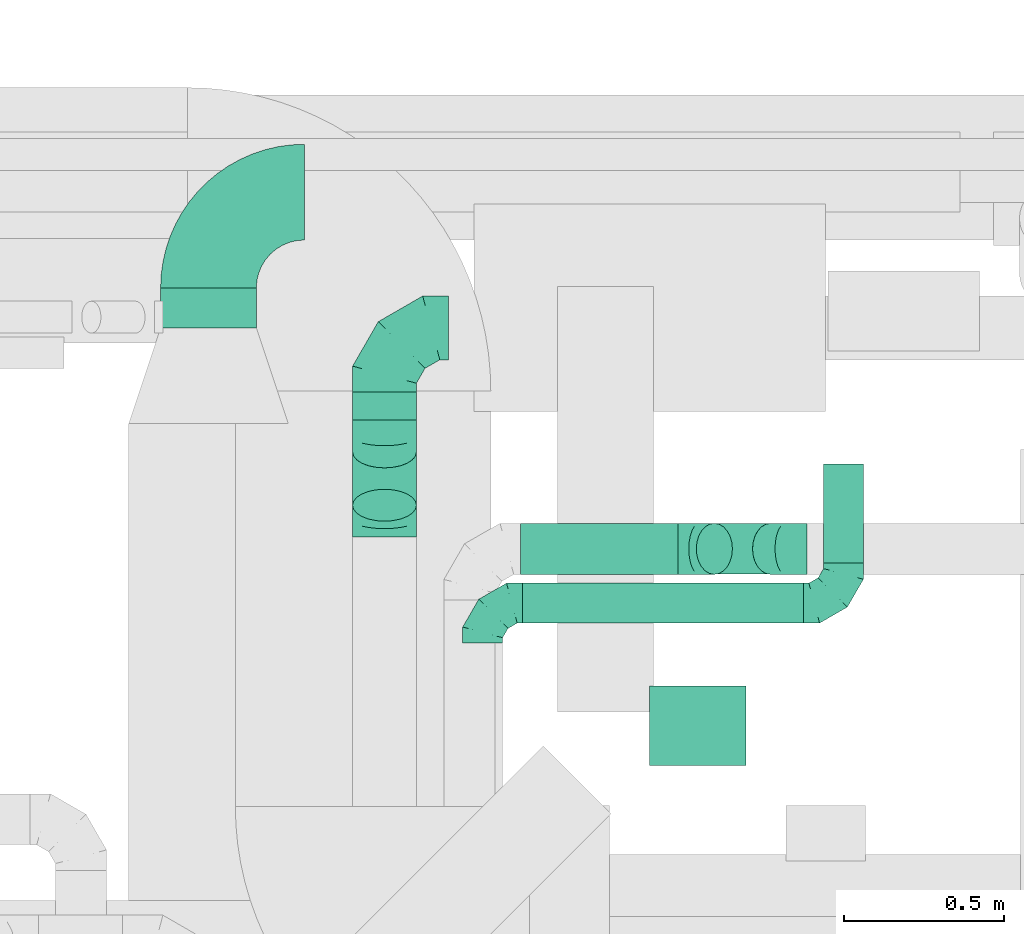
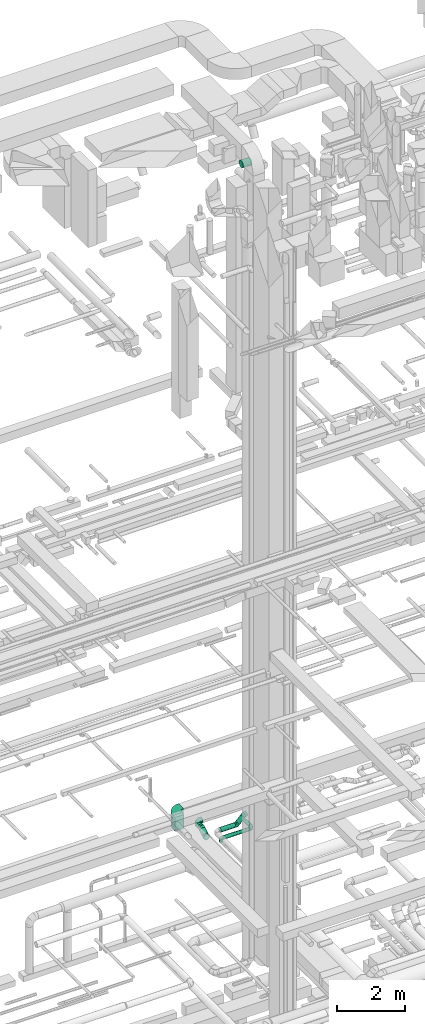
# One storey, part 280 of 337: 8 flow fittings, 8 flow segments.
"""IFC2X3 building model written with IfcOpenShell, lengths in millimetres."""

from ifc_helpers import new_model, entity, si_unit, converted_unit, derived_unit, direction, frame, frame_2d, origin, origin_2d_with_axis, place, context, subcontext, project, spatial, polyline, circle_curve, parameter, trimmed, segment, composite_curve, rectangle, circle, outline, extrude, faceted_brep, source, transform, mapped, material, type_object, type_shapes, element, save


model = new_model("IFC2X3")

# Units and contexts
model_context = context("Model", 3, precision=0.01, world=origin(), true_north=direction((6.12303176911189e-17, 1.0)))
body_context = subcontext(model_context, "Body", "Model", "MODEL_VIEW")
ifc_project = project(units=[si_unit("LENGTHUNIT", "METRE", prefix="MILLI"), si_unit("AREAUNIT", "SQUARE_METRE"), si_unit("VOLUMEUNIT", "CUBIC_METRE"), converted_unit("PLANEANGLEUNIT", "DEGREE", entity("IfcRatioMeasure", 0.0174532925199433), si_unit("PLANEANGLEUNIT", "RADIAN"), dimensions=[0, 0, 0, 0, 0, 0, 0]), si_unit("MASSUNIT", "GRAM", prefix="KILO"), derived_unit("MASSDENSITYUNIT", [(si_unit("MASSUNIT", "GRAM", prefix="KILO"), 1), (si_unit("LENGTHUNIT", "METRE"), -3)]), derived_unit("MOMENTOFINERTIAUNIT", [(si_unit("LENGTHUNIT", "METRE"), 4)]), si_unit("TIMEUNIT", "SECOND"), si_unit("FREQUENCYUNIT", "HERTZ"), si_unit("THERMODYNAMICTEMPERATUREUNIT", "DEGREE_CELSIUS"), derived_unit("THERMALTRANSMITTANCEUNIT", [(si_unit("MASSUNIT", "GRAM", prefix="KILO"), 1), (si_unit("THERMODYNAMICTEMPERATUREUNIT", "KELVIN"), -1), (si_unit("TIMEUNIT", "SECOND"), -3)]), derived_unit("VOLUMETRICFLOWRATEUNIT", [(si_unit("LENGTHUNIT", "METRE"), 3), (si_unit("TIMEUNIT", "SECOND"), -1)]), derived_unit("MASSFLOWRATEUNIT", [(si_unit("MASSUNIT", "GRAM", prefix="KILO"), 1), (si_unit("TIMEUNIT", "SECOND"), -1)]), derived_unit("ROTATIONALFREQUENCYUNIT", [(si_unit("TIMEUNIT", "SECOND"), -1)]), si_unit("ELECTRICCURRENTUNIT", "AMPERE"), si_unit("ELECTRICVOLTAGEUNIT", "VOLT"), si_unit("POWERUNIT", "WATT"), si_unit("FORCEUNIT", "NEWTON", prefix="KILO"), si_unit("ILLUMINANCEUNIT", "LUX"), si_unit("LUMINOUSFLUXUNIT", "LUMEN"), si_unit("LUMINOUSINTENSITYUNIT", "CANDELA"), derived_unit("USERDEFINED", [(si_unit("MASSUNIT", "GRAM", prefix="KILO"), -1), (si_unit("LENGTHUNIT", "METRE"), -2), (si_unit("TIMEUNIT", "SECOND"), 3), (si_unit("LUMINOUSFLUXUNIT", "LUMEN"), 1)]), derived_unit("LINEARVELOCITYUNIT", [(si_unit("LENGTHUNIT", "METRE"), 1), (si_unit("TIMEUNIT", "SECOND"), -1)]), si_unit("PRESSUREUNIT", "PASCAL"), derived_unit("USERDEFINED", [(si_unit("LENGTHUNIT", "METRE"), -2), (si_unit("MASSUNIT", "GRAM", prefix="KILO"), 1), (si_unit("TIMEUNIT", "SECOND"), -2)]), derived_unit("LINEARFORCEUNIT", [(si_unit("MASSUNIT", "GRAM", prefix="KILO"), 1), (si_unit("LENGTHUNIT", "METRE"), 1), (si_unit("TIMEUNIT", "SECOND"), -2), (si_unit("LENGTHUNIT", "METRE"), -1)]), derived_unit("PLANARFORCEUNIT", [(si_unit("MASSUNIT", "GRAM", prefix="KILO"), 1), (si_unit("LENGTHUNIT", "METRE"), 1), (si_unit("TIMEUNIT", "SECOND"), -2), (si_unit("LENGTHUNIT", "METRE"), -2)])], contexts=[model_context])

# Site, building, storey
site_placement = place(None, origin())
site = spatial("IfcSite", under=ifc_project, at=site_placement, CompositionType="ELEMENT")
building_placement = place(site_placement, origin())
building = spatial("IfcBuilding", under=site, at=building_placement, CompositionType="ELEMENT")
storey_placement = place(building_placement, origin())
storey = spatial("IfcBuildingStorey", under=building, at=storey_placement, CompositionType="ELEMENT", Elevation=0.0)

# Flow segments
duct_segment_type_1 = type_object("IfcDuctSegmentType", PredefinedType="NOTDEFINED")
flow_segment_1_placement = place(storey_placement, frame((46175.84, 19371.07, 3200.0)))
element("IfcFlowSegment", 1, at=flow_segment_1_placement, inside=storey, type_object=duct_segment_type_1, context=body_context, shape_type="SweptSolid", body=[
    extrude(rectangle(XDim=125.172819427906, YDim=300.000000000001, at=origin_2d_with_axis()), frame((150.0, 62.59, 0.0), z_axis=(0.0, 0.0, 1.0), x_axis=(0.0, -1.0, 0.0)), (0.0, 0.0, 1.0), 500.0),
])
duct_segment_type_2 = type_object("IfcDuctSegmentType", PredefinedType="NOTDEFINED")
flow_segment_2_placement = place(storey_placement, frame((47309.59, 18445.02, 3035.9)))
element("IfcFlowSegment", 2, at=flow_segment_2_placement, inside=storey, type_object=duct_segment_type_2, context=body_context, shape_type="SweptSolid", body=[
    extrude(circle(Radius=62.5, at=origin_2d_with_axis()), frame((0.0, 64.1, 64.1), z_axis=(1.0, 0.0, 0.0), x_axis=(0.0, -1.0, 0.0)), (0.0, 0.0, 1.0), 880.000000000043),
])
flow_segment_3_placement = place(storey_placement, frame((47706.43, 17998.76, 27323.4)))
element("IfcFlowSegment", 3, at=flow_segment_3_placement, inside=storey, type_object=duct_segment_type_2, context=body_context, shape_type="SweptSolid", body=[
    extrude(circle(Radius=125.0, at=origin_2d_with_axis()), frame((0.0, 126.6, 126.6), z_axis=(1.0, 0.0, 0.0), x_axis=(0.0, -1.0, 0.0)), (0.0, 0.0, 1.0), 302.500000000001),
])
flow_segment_4_placement = place(storey_placement, frame((48250.5, 18634.11, 3035.9)))
element("IfcFlowSegment", 4, at=flow_segment_4_placement, inside=storey, type_object=duct_segment_type_2, context=body_context, shape_type="SweptSolid", body=[
    extrude(circle(Radius=62.5, at=origin_2d_with_axis()), frame((64.1, 0.0, 64.1), z_axis=(0.0, 1.0, 0.0), x_axis=(1.0, 0.0, 0.0)), (0.0, 0.0, 1.0), 310.00000000002),
])
flow_segment_5_placement = place(storey_placement, frame((47303.34, 18597.52, 3198.4)))
element("IfcFlowSegment", 5, at=flow_segment_5_placement, inside=storey, type_object=duct_segment_type_2, context=body_context, shape_type="SweptSolid", body=[
    extrude(circle(Radius=80.0, at=origin_2d_with_axis()), frame((0.0, 81.6, 81.6), z_axis=(1.0, 0.0, 0.0), x_axis=(0.0, -1.0, 0.0)), (0.0, 0.0, 1.0), 493.72583002049),
])
flow_segment_6_placement = place(storey_placement, frame((47852.04, 18597.52, 3268.7)))
element("IfcFlowSegment", 6, at=flow_segment_6_placement, inside=storey, type_object=duct_segment_type_2, context=body_context, shape_type="SweptSolid", body=[
    extrude(circle(Radius=80.0, at=origin_2d_with_axis()), frame((58.16, 81.6, 58.16), z_axis=(0.707106781186545, 0.0, 0.70710678118655), x_axis=(0.0, 1.0, 0.0)), (0.0, 0.0, 1.0), 249.289321881311),
])
flow_segment_7_placement = place(storey_placement, frame((46775.59, 19082.7, 3198.4)))
element("IfcFlowSegment", 7, at=flow_segment_7_placement, inside=storey, type_object=duct_segment_type_2, context=body_context, shape_type="SweptSolid", body=[
    extrude(circle(Radius=100.0, at=origin_2d_with_axis()), frame((101.6, 0.0, 101.6), z_axis=(0.0, 1.0, 0.0), x_axis=(-1.0, 0.0, 0.0)), (0.0, 0.0, 1.0), 88.3703419238146),
])
flow_segment_8_placement = place(storey_placement, frame((46775.59, 18764.12, 3088.6)))
element("IfcFlowSegment", 8, at=flow_segment_8_placement, inside=storey, type_object=duct_segment_type_2, context=body_context, shape_type="SweptSolid", body=[
    extrude(circle(Radius=100.0, at=origin_2d_with_axis()), frame((101.6, 51.6, 88.2), z_axis=(0.0, 0.866025410712643, 0.499999987999998), x_axis=(-1.0, 0.0, 0.0)), (0.0, 0.0, 1.0), 192.820333197818),
])

# Flow fittings
ifc_material = material()
duct_fitting_type_1 = type_object("IfcDuctFittingType", PredefinedType="NOTDEFINED", material=ifc_material)
shared_shape_1 = source(origin(), body_context, "Body", "Brep", [
    faceted_brep([(-200.0, 0.0, -100.0), (-200.0, -25.88, -96.59), (-200.0, -50.0, -86.6), (-200.0, -70.71, -70.71), (-200.0, -86.6, -50.0), (-200.0, -96.59, -25.88), (-200.0, -100.0, 0.0), (-200.0, -96.59, 25.88), (-200.0, -86.6, 50.0), (-200.0, -70.71, 70.71), (-200.0, -50.0, 86.6), (-200.0, -25.88, 96.59), (-200.0, 0.0, 100.0), (-200.0, 25.88, 96.59), (-200.0, 50.0, 86.6), (-200.0, 70.71, 70.71), (-200.0, 86.6, 50.0), (-200.0, 96.59, 25.88), (-200.0, 100.0, 0.0), (-200.0, 96.59, -25.88), (-200.0, 86.6, -50.0), (-200.0, 70.71, -70.71), (-200.0, 50.0, -86.6), (-200.0, 25.88, -96.59), (-153.35, 25.88, 96.59), (-159.81, 50.0, 86.6), (-146.41, 0.0, 100.0), (-165.36, 70.71, 70.71), (-172.29, 96.59, 25.88), (-173.21, 100.0, 0.0), (-169.62, 86.6, 50.0), (-169.62, 86.6, -50.0), (-165.36, 70.71, -70.71), (-172.29, 96.59, -25.88), (-153.35, 25.88, -96.59), (-146.41, 0.0, -100.0), (-159.81, 50.0, -86.6), (-139.48, -25.88, -96.59), (-133.01, -50.0, -86.6), (-127.46, -70.71, -70.71), (-123.21, -86.6, -50.0), (-120.53, -96.59, -25.88), (-119.62, -100.0, 0.0), (-120.53, -96.59, 25.88), (-123.21, -86.6, 50.0), (-127.46, -70.71, 70.71), (-133.01, -50.0, 86.6), (-139.48, -25.88, 96.59), (-72.54, 72.54, 96.59), (-90.19, 90.19, 86.6), (-53.59, 53.59, 100.0), (-105.35, 105.35, 70.71), (-116.99, 116.99, 50.0), (-124.3, 124.3, 25.88), (-126.79, 126.79, 0.0), (-124.3, 124.3, -25.88), (-116.99, 116.99, -50.0), (-105.35, 105.35, -70.71), (-72.54, 72.54, -96.59), (-53.59, 53.59, -100.0), (-90.19, 90.19, -86.6), (-34.64, 34.64, -96.59), (-16.99, 16.99, -86.6), (-1.83, 1.83, -70.71), (9.81, -9.81, -50.0), (17.12, -17.12, -25.88), (19.62, -19.62, 0.0), (17.12, -17.12, 25.88), (9.81, -9.81, 50.0), (-1.83, 1.83, 70.71), (-16.99, 16.99, 86.6), (-34.64, 34.64, 96.59), (-25.88, 153.35, 96.59), (-50.0, 159.81, 86.6), (0.0, 146.41, 100.0), (-70.71, 165.36, 70.71), (-86.6, 169.62, 50.0), (-96.59, 172.29, 25.88), (-100.0, 173.21, 0.0), (-96.59, 172.29, -25.88), (-86.6, 169.62, -50.0), (-70.71, 165.36, -70.71), (-25.88, 153.35, -96.59), (0.0, 146.41, -100.0), (-50.0, 159.81, -86.6), (25.88, 139.48, -96.59), (50.0, 133.01, -86.6), (70.71, 127.46, -70.71), (86.6, 123.21, -50.0), (96.59, 120.53, -25.88), (100.0, 119.62, 0.0), (96.59, 120.53, 25.88), (86.6, 123.21, 50.0), (70.71, 127.46, 70.71), (50.0, 133.01, 86.6), (25.88, 139.48, 96.59), (-25.88, 200.0, -96.59), (-50.0, 200.0, -86.6), (-70.71, 200.0, -70.71), (-86.6, 200.0, -50.0), (-96.59, 200.0, -25.88), (-100.0, 200.0, 0.0), (-96.59, 200.0, 25.88), (-86.6, 200.0, 50.0), (-70.71, 200.0, 70.71), (-50.0, 200.0, 86.6), (-25.88, 200.0, 96.59), (0.0, 200.0, 100.0), (25.88, 200.0, 96.59), (50.0, 200.0, 86.6), (70.71, 200.0, 70.71), (86.6, 200.0, 50.0), (96.59, 200.0, 25.88), (100.0, 200.0, 0.0), (96.59, 200.0, -25.88), (86.6, 200.0, -50.0), (70.71, 200.0, -70.71), (50.0, 200.0, -86.6), (25.88, 200.0, -96.59), (0.0, 200.0, -100.0)], [[[0, 1, 2, 3, 4, 5, 6, 7, 8, 9, 10, 11, 12, 13, 14, 15, 16, 17, 18, 19, 20, 21, 22, 23]], [[24, 25, 14, 13]], [[26, 24, 13, 12]], [[14, 25, 27, 15]], [[28, 29, 18, 17]], [[30, 28, 17, 16]], [[15, 27, 30, 16]], [[20, 31, 32, 21]], [[33, 31, 20, 19]], [[18, 29, 33, 19]], [[34, 35, 0, 23]], [[36, 34, 23, 22]], [[32, 36, 22, 21]], [[1, 0, 35, 37]], [[2, 1, 37, 38]], [[38, 39, 3, 2]], [[5, 4, 40, 41]], [[6, 5, 41, 42]], [[39, 40, 4, 3]], [[6, 42, 43, 7]], [[7, 43, 44, 8]], [[8, 44, 45, 9]], [[9, 45, 46, 10]], [[10, 46, 47, 11]], [[26, 12, 11, 47]], [[48, 49, 25, 24]], [[50, 48, 24, 26]], [[27, 25, 49, 51]], [[52, 53, 28, 30]], [[51, 52, 30, 27]], [[29, 28, 53, 54]], [[55, 56, 31, 33]], [[54, 55, 33, 29]], [[32, 31, 56, 57]], [[58, 59, 35, 34]], [[60, 58, 34, 36]], [[57, 60, 36, 32]], [[37, 35, 59, 61]], [[38, 37, 61, 62]], [[39, 38, 62, 63]], [[41, 40, 64, 65]], [[42, 41, 65, 66]], [[63, 64, 40, 39]], [[43, 42, 66, 67]], [[44, 43, 67, 68]], [[68, 69, 45, 44]], [[46, 45, 69, 70]], [[47, 46, 70, 71]], [[26, 47, 71, 50]], [[72, 73, 49, 48]], [[74, 72, 48, 50]], [[51, 49, 73, 75]], [[76, 77, 53, 52]], [[75, 76, 52, 51]], [[54, 53, 77, 78]], [[79, 80, 56, 55]], [[78, 79, 55, 54]], [[57, 56, 80, 81]], [[82, 83, 59, 58]], [[84, 82, 58, 60]], [[81, 84, 60, 57]], [[61, 59, 83, 85]], [[62, 61, 85, 86]], [[63, 62, 86, 87]], [[65, 64, 88, 89]], [[66, 65, 89, 90]], [[87, 88, 64, 63]], [[67, 66, 90, 91]], [[68, 67, 91, 92]], [[92, 93, 69, 68]], [[70, 69, 93, 94]], [[71, 70, 94, 95]], [[50, 71, 95, 74]], [[96, 97, 98, 99, 100, 101, 102, 103, 104, 105, 106, 107, 108, 109, 110, 111, 112, 113, 114, 115, 116, 117, 118, 119]], [[72, 74, 107, 106]], [[73, 72, 106, 105]], [[75, 73, 105, 104]], [[102, 101, 78, 77]], [[103, 102, 77, 76]], [[75, 104, 103, 76]], [[78, 101, 100, 79]], [[79, 100, 99, 80]], [[80, 99, 98, 81]], [[84, 97, 96, 82]], [[82, 96, 119, 83]], [[84, 81, 98, 97]], [[118, 117, 86, 85]], [[119, 118, 85, 83]], [[116, 87, 86, 117]], [[88, 115, 114, 89]], [[89, 114, 113, 90]], [[115, 88, 87, 116]], [[91, 90, 113, 112]], [[92, 91, 112, 111]], [[111, 110, 93, 92]], [[95, 94, 109, 108]], [[74, 95, 108, 107]], [[110, 109, 94, 93]]]),
])
type_shapes(duct_fitting_type_1, [shared_shape_1])
flow_fitting_1_placement = place(storey_placement, frame((46877.19, 19371.07, 3300.0), z_axis=(0.0, 0.0, 1.0), x_axis=(-1.0, 0.0, 0.0)))
element("IfcFlowFitting", 9, at=flow_fitting_1_placement, inside=storey, type_object=duct_fitting_type_1, material=ifc_material, context=body_context, shape_type="MappedRepresentation", body=[
    mapped(shared_shape_1, transform((0.0, 0.0, 0.0), scale=1.0)),
])
duct_fitting_type_2 = type_object("IfcDuctFittingType", PredefinedType="NOTDEFINED", material=ifc_material)
shared_shape_2 = source(origin(), body_context, "Body", "Brep", [
    faceted_brep([(-125.0, 0.0, -62.5), (-125.0, -16.18, -60.37), (-125.0, -31.25, -54.13), (-125.0, -44.19, -44.19), (-125.0, -54.13, -31.25), (-125.0, -60.37, -16.18), (-125.0, -62.5, 0.0), (-125.0, -60.37, 16.18), (-125.0, -54.13, 31.25), (-125.0, -44.19, 44.19), (-125.0, -31.25, 54.13), (-125.0, -16.18, 60.37), (-125.0, 0.0, 62.5), (-125.0, 16.18, 60.37), (-125.0, 31.25, 54.13), (-125.0, 44.19, 44.19), (-125.0, 54.13, 31.25), (-125.0, 60.37, 16.18), (-125.0, 62.5, 0.0), (-125.0, 60.37, -16.18), (-125.0, 54.13, -31.25), (-125.0, 44.19, -44.19), (-125.0, 31.25, -54.13), (-125.0, 16.18, -60.37), (-95.84, 16.18, 60.37), (-99.88, 31.25, 54.13), (-91.51, 0.0, 62.5), (-103.35, 44.19, 44.19), (-107.68, 60.37, 16.18), (-108.25, 62.5, 0.0), (-106.01, 54.13, 31.25), (-106.01, 54.13, -31.25), (-103.35, 44.19, -44.19), (-107.68, 60.37, -16.18), (-95.84, 16.18, -60.37), (-91.51, 0.0, -62.5), (-99.88, 31.25, -54.13), (-87.17, -16.18, -60.37), (-83.13, -31.25, -54.13), (-79.66, -44.19, -44.19), (-77.0, -54.13, -31.25), (-75.33, -60.37, -16.18), (-74.76, -62.5, 0.0), (-75.33, -60.37, 16.18), (-77.0, -54.13, 31.25), (-79.66, -44.19, 44.19), (-83.13, -31.25, 54.13), (-87.17, -16.18, 60.37), (-45.34, 45.34, 60.37), (-56.37, 56.37, 54.13), (-33.49, 33.49, 62.5), (-65.85, 65.85, 44.19), (-73.12, 73.12, 31.25), (-77.69, 77.69, 16.18), (-79.25, 79.25, 0.0), (-77.69, 77.69, -16.18), (-73.12, 73.12, -31.25), (-65.85, 65.85, -44.19), (-45.34, 45.34, -60.37), (-33.49, 33.49, -62.5), (-56.37, 56.37, -54.13), (-21.65, 21.65, -60.37), (-10.62, 10.62, -54.13), (-1.14, 1.14, -44.19), (6.13, -6.13, -31.25), (10.7, -10.7, -16.18), (12.26, -12.26, 0.0), (10.7, -10.7, 16.18), (6.13, -6.13, 31.25), (-1.14, 1.14, 44.19), (-10.62, 10.62, 54.13), (-21.65, 21.65, 60.37), (-16.18, 95.84, 60.37), (-31.25, 99.88, 54.13), (0.0, 91.51, 62.5), (-44.19, 103.35, 44.19), (-54.13, 106.01, 31.25), (-60.37, 107.68, 16.18), (-62.5, 108.25, 0.0), (-60.37, 107.68, -16.18), (-54.13, 106.01, -31.25), (-44.19, 103.35, -44.19), (-16.18, 95.84, -60.37), (0.0, 91.51, -62.5), (-31.25, 99.88, -54.13), (16.18, 87.17, -60.37), (31.25, 83.13, -54.13), (44.19, 79.66, -44.19), (54.13, 77.0, -31.25), (60.37, 75.33, -16.18), (62.5, 74.76, 0.0), (60.37, 75.33, 16.18), (54.13, 77.0, 31.25), (44.19, 79.66, 44.19), (31.25, 83.13, 54.13), (16.18, 87.17, 60.37), (-16.18, 125.0, -60.37), (-31.25, 125.0, -54.13), (-44.19, 125.0, -44.19), (-54.13, 125.0, -31.25), (-60.37, 125.0, -16.18), (-62.5, 125.0, 0.0), (-60.37, 125.0, 16.18), (-54.13, 125.0, 31.25), (-44.19, 125.0, 44.19), (-31.25, 125.0, 54.13), (-16.18, 125.0, 60.37), (0.0, 125.0, 62.5), (16.18, 125.0, 60.37), (31.25, 125.0, 54.13), (44.19, 125.0, 44.19), (54.13, 125.0, 31.25), (60.37, 125.0, 16.18), (62.5, 125.0, 0.0), (60.37, 125.0, -16.18), (54.13, 125.0, -31.25), (44.19, 125.0, -44.19), (31.25, 125.0, -54.13), (16.18, 125.0, -60.37), (0.0, 125.0, -62.5)], [[[0, 1, 2, 3, 4, 5, 6, 7, 8, 9, 10, 11, 12, 13, 14, 15, 16, 17, 18, 19, 20, 21, 22, 23]], [[24, 25, 14, 13]], [[26, 24, 13, 12]], [[14, 25, 27, 15]], [[28, 29, 18, 17]], [[30, 28, 17, 16]], [[15, 27, 30, 16]], [[20, 31, 32, 21]], [[33, 31, 20, 19]], [[18, 29, 33, 19]], [[34, 35, 0, 23]], [[36, 34, 23, 22]], [[21, 32, 36, 22]], [[1, 0, 35, 37]], [[2, 1, 37, 38]], [[38, 39, 3, 2]], [[5, 4, 40, 41]], [[6, 5, 41, 42]], [[39, 40, 4, 3]], [[6, 42, 43, 7]], [[7, 43, 44, 8]], [[45, 9, 8, 44]], [[9, 45, 46, 10]], [[10, 46, 47, 11]], [[26, 12, 11, 47]], [[48, 49, 25, 24]], [[50, 48, 24, 26]], [[27, 25, 49, 51]], [[52, 53, 28, 30]], [[51, 52, 30, 27]], [[29, 28, 53, 54]], [[55, 56, 31, 33]], [[54, 55, 33, 29]], [[57, 32, 31, 56]], [[58, 59, 35, 34]], [[60, 58, 34, 36]], [[57, 60, 36, 32]], [[37, 35, 59, 61]], [[38, 37, 61, 62]], [[39, 38, 62, 63]], [[41, 40, 64, 65]], [[42, 41, 65, 66]], [[63, 64, 40, 39]], [[43, 42, 66, 67]], [[44, 43, 67, 68]], [[68, 69, 45, 44]], [[46, 45, 69, 70]], [[47, 46, 70, 71]], [[26, 47, 71, 50]], [[72, 73, 49, 48]], [[74, 72, 48, 50]], [[51, 49, 73, 75]], [[76, 77, 53, 52]], [[75, 76, 52, 51]], [[54, 53, 77, 78]], [[79, 80, 56, 55]], [[78, 79, 55, 54]], [[81, 57, 56, 80]], [[82, 83, 59, 58]], [[84, 82, 58, 60]], [[81, 84, 60, 57]], [[61, 59, 83, 85]], [[62, 61, 85, 86]], [[63, 62, 86, 87]], [[65, 64, 88, 89]], [[66, 65, 89, 90]], [[87, 88, 64, 63]], [[67, 66, 90, 91]], [[68, 67, 91, 92]], [[92, 93, 69, 68]], [[70, 69, 93, 94]], [[71, 70, 94, 95]], [[50, 71, 95, 74]], [[96, 97, 98, 99, 100, 101, 102, 103, 104, 105, 106, 107, 108, 109, 110, 111, 112, 113, 114, 115, 116, 117, 118, 119]], [[72, 74, 107, 106]], [[73, 72, 106, 105]], [[75, 73, 105, 104]], [[77, 76, 103, 102]], [[78, 77, 102, 101]], [[75, 104, 103, 76]], [[78, 101, 100, 79]], [[79, 100, 99, 80]], [[80, 99, 98, 81]], [[96, 119, 83, 82]], [[97, 96, 82, 84]], [[84, 81, 98, 97]], [[83, 119, 118, 85]], [[85, 118, 117, 86]], [[116, 87, 86, 117]], [[88, 115, 114, 89]], [[89, 114, 113, 90]], [[115, 88, 87, 116]], [[91, 90, 113, 112]], [[92, 91, 112, 111]], [[111, 110, 93, 92]], [[95, 94, 109, 108]], [[74, 95, 108, 107]], [[110, 109, 94, 93]]]),
])
type_shapes(duct_fitting_type_2, [shared_shape_2])
flow_fitting_2_placement = place(storey_placement, frame((47184.59, 18509.11, 3100.0), z_axis=(0.0, 0.0, 1.0), x_axis=(-1.0, 0.0, 0.0)))
element("IfcFlowFitting", 10, at=flow_fitting_2_placement, inside=storey, type_object=duct_fitting_type_2, material=ifc_material, context=body_context, shape_type="MappedRepresentation", body=[
    mapped(shared_shape_2, transform((0.0, 0.0, 0.0), scale=1.0)),
])
flow_fitting_3_placement = place(storey_placement, frame((48314.59, 18509.11, 3100.0)))
element("IfcFlowFitting", 11, at=flow_fitting_3_placement, inside=storey, type_object=duct_fitting_type_2, material=ifc_material, context=body_context, shape_type="MappedRepresentation", body=[
    mapped(shared_shape_2, transform((0.0, 0.0, 0.0), scale=1.0)),
])
duct_fitting_type_3 = type_object("IfcDuctFittingType", PredefinedType="NOTDEFINED", material=ifc_material)
shared_shape_3 = source(origin(), body_context, "Body", "Brep", [
    faceted_brep([(-66.27, 0.0, -80.0), (-66.27, -20.71, -77.27), (-66.27, -40.0, -69.28), (-66.27, -56.57, -56.57), (-66.27, -69.28, -40.0), (-66.27, -77.27, -20.71), (-66.27, -80.0, 0.0), (-66.27, -77.27, 20.71), (-66.27, -69.28, 40.0), (-66.27, -56.57, 56.57), (-66.27, -40.0, 69.28), (-66.27, -20.71, 77.27), (-66.27, 0.0, 80.0), (-66.27, 20.71, 77.27), (-66.27, 40.0, 69.28), (-66.27, 56.57, 56.57), (-66.27, 69.28, 40.0), (-66.27, 77.27, 20.71), (-66.27, 80.0, 0.0), (-66.27, 77.27, -20.71), (-66.27, 69.28, -40.0), (-66.27, 56.57, -56.57), (-66.27, 40.0, -69.28), (-66.27, 20.71, -77.27), (-8.58, 20.71, 77.27), (-16.57, 40.0, 69.28), (0.0, 0.0, 80.0), (-23.43, 56.57, 56.57), (-28.7, 69.28, 40.0), (-32.01, 77.27, 20.71), (-33.14, 80.0, 0.0), (-32.01, 77.27, -20.71), (-28.7, 69.28, -40.0), (-23.43, 56.57, -56.57), (-8.58, 20.71, -77.27), (0.0, 0.0, -80.0), (-16.57, 40.0, -69.28), (8.58, -20.71, -77.27), (16.57, -40.0, -69.28), (23.43, -56.57, -56.57), (28.7, -69.28, -40.0), (32.01, -77.27, -20.71), (33.14, -80.0, 0.0), (32.01, -77.27, 20.71), (28.7, -69.28, 40.0), (23.43, -56.57, 56.57), (16.57, -40.0, 69.28), (8.58, -20.71, 77.27), (46.86, 46.86, 80.0), (32.22, 61.5, 77.27), (18.58, 75.15, 69.28), (6.86, 86.86, 56.57), (-2.13, 95.85, 40.0), (-7.78, 101.5, 20.71), (-9.71, 103.43, 0.0), (-7.78, 101.5, -20.71), (-2.13, 95.85, -40.0), (6.86, 86.86, -56.57), (18.58, 75.15, -69.28), (32.22, 61.5, -77.27), (46.86, 46.86, -80.0), (61.5, 32.22, -77.27), (75.15, 18.58, -69.28), (86.86, 6.86, -56.57), (95.85, -2.13, -40.0), (101.5, -7.78, -20.71), (103.43, -9.71, 0.0), (101.5, -7.78, 20.71), (95.85, -2.13, 40.0), (86.86, 6.86, 56.57), (75.15, 18.58, 69.28), (61.5, 32.22, 77.27)], [[[0, 1, 2, 3, 4, 5, 6, 7, 8, 9, 10, 11, 12, 13, 14, 15, 16, 17, 18, 19, 20, 21, 22, 23]], [[24, 25, 14, 13]], [[26, 24, 13, 12]], [[14, 25, 27, 15]], [[28, 29, 17, 16]], [[28, 16, 15, 27]], [[30, 18, 17, 29]], [[31, 32, 20, 19]], [[30, 31, 19, 18]], [[32, 33, 21, 20]], [[34, 35, 0, 23]], [[36, 34, 23, 22]], [[33, 36, 22, 21]], [[1, 0, 35, 37]], [[2, 1, 37, 38]], [[38, 39, 3, 2]], [[5, 4, 40, 41]], [[6, 5, 41, 42]], [[39, 40, 4, 3]], [[6, 42, 43, 7]], [[7, 43, 44, 8]], [[8, 44, 45, 9]], [[9, 45, 46, 10]], [[10, 46, 47, 11]], [[26, 12, 11, 47]], [[24, 26, 48, 49]], [[25, 24, 49, 50]], [[27, 25, 50, 51]], [[29, 28, 52, 53]], [[30, 29, 53, 54]], [[51, 52, 28, 27]], [[30, 54, 55, 31]], [[31, 55, 56, 32]], [[57, 33, 32, 56]], [[36, 58, 59, 34]], [[34, 59, 60, 35]], [[58, 36, 33, 57]], [[35, 60, 61, 37]], [[37, 61, 62, 38]], [[63, 39, 38, 62]], [[40, 64, 65, 41]], [[41, 65, 66, 42]], [[64, 40, 39, 63]], [[43, 42, 66, 67]], [[44, 43, 67, 68]], [[68, 69, 45, 44]], [[47, 46, 70, 71]], [[26, 47, 71, 48]], [[69, 70, 46, 45]], [[59, 58, 57, 56, 55, 54, 53, 52, 51, 50, 49, 48, 71, 70, 69, 68, 67, 66, 65, 64, 63, 62, 61, 60]]]),
])
type_shapes(duct_fitting_type_3, [shared_shape_3])
for number, where, z_axis, x_axis in (
    (12, (48133.34, 18679.11, 3550.0), (0.0, -1.0, 0.0), (-1.0, 0.0, 0.0)),
    (13, (47863.34, 18679.11, 3280.0), (0.0, -1.0, 0.0), (1.0, 0.0, 0.0)),
):
    element("IfcFlowFitting", number, at=place(storey_placement, frame(where, z_axis=z_axis, x_axis=x_axis)), inside=storey, type_object=duct_fitting_type_3, material=ifc_material, context=body_context, shape_type="MappedRepresentation", body=[
        mapped(shared_shape_3, transform((0.0, 0.0, 0.0), scale=1.0)),
    ])
duct_fitting_type_4 = type_object("IfcDuctFittingType", PredefinedType="NOTDEFINED", material=ifc_material)
shared_shape_4 = source(origin(), body_context, "Body", "Brep", [
    faceted_brep([(-53.59, 0.0, -100.0), (-53.59, -25.88, -96.59), (-53.59, -50.0, -86.6), (-53.59, -70.71, -70.71), (-53.59, -86.6, -50.0), (-53.59, -96.59, -25.88), (-53.59, -100.0, 0.0), (-53.59, -96.59, 25.88), (-53.59, -86.6, 50.0), (-53.59, -70.71, 70.71), (-53.59, -50.0, 86.6), (-53.59, -25.88, 96.59), (-53.59, 0.0, 100.0), (-53.59, 25.88, 96.59), (-53.59, 50.0, 86.6), (-53.59, 70.71, 70.71), (-53.59, 86.6, 50.0), (-53.59, 96.59, 25.88), (-53.59, 100.0, 0.0), (-53.59, 96.59, -25.88), (-53.59, 86.6, -50.0), (-53.59, 70.71, -70.71), (-53.59, 50.0, -86.6), (-53.59, 25.88, -96.59), (-6.94, 25.88, 96.59), (-13.4, 50.0, 86.6), (0.0, 0.0, 100.0), (-18.95, 70.71, 70.71), (-25.88, 96.59, 25.88), (-26.79, 100.0, 0.0), (-23.21, 86.6, 50.0), (-23.21, 86.6, -50.0), (-18.95, 70.71, -70.71), (-25.88, 96.59, -25.88), (-6.94, 25.88, -96.59), (0.0, 0.0, -100.0), (-13.4, 50.0, -86.6), (6.94, -25.88, -96.59), (13.4, -50.0, -86.6), (18.95, -70.71, -70.71), (23.21, -86.6, -50.0), (25.88, -96.59, -25.88), (26.79, -100.0, 0.0), (25.88, -96.59, 25.88), (23.21, -86.6, 50.0), (18.95, -70.71, 70.71), (13.4, -50.0, 86.6), (6.94, -25.88, 96.59), (46.41, 26.79, 100.0), (33.47, 49.21, 96.59), (21.41, 70.1, 86.6), (11.05, 88.03, 70.71), (-1.89, 110.45, 25.88), (-3.59, 113.4, 0.0), (3.11, 101.79, 50.0), (-1.89, 110.45, -25.88), (3.11, 101.79, -50.0), (11.05, 88.03, -70.71), (21.41, 70.1, -86.6), (33.47, 49.21, -96.59), (46.41, 26.79, -100.0), (59.35, 4.38, -96.59), (71.41, -16.51, -86.6), (81.77, -34.44, -70.71), (89.71, -48.21, -50.0), (94.71, -56.86, -25.88), (96.41, -59.81, 0.0), (94.71, -56.86, 25.88), (89.71, -48.21, 50.0), (81.77, -34.44, 70.71), (71.41, -16.51, 86.6), (59.35, 4.38, 96.59)], [[[0, 1, 2, 3, 4, 5, 6, 7, 8, 9, 10, 11, 12, 13, 14, 15, 16, 17, 18, 19, 20, 21, 22, 23]], [[24, 25, 14, 13]], [[26, 24, 13, 12]], [[14, 25, 27, 15]], [[28, 29, 18, 17]], [[30, 28, 17, 16]], [[15, 27, 30, 16]], [[20, 31, 32, 21]], [[33, 31, 20, 19]], [[18, 29, 33, 19]], [[34, 35, 0, 23]], [[36, 34, 23, 22]], [[32, 36, 22, 21]], [[1, 0, 35, 37]], [[2, 1, 37, 38]], [[38, 39, 3, 2]], [[5, 4, 40, 41]], [[6, 5, 41, 42]], [[39, 40, 4, 3]], [[6, 42, 43, 7]], [[7, 43, 44, 8]], [[8, 44, 45, 9]], [[9, 45, 46, 10]], [[10, 46, 47, 11]], [[26, 12, 11, 47]], [[24, 26, 48, 49]], [[25, 24, 49, 50]], [[27, 25, 50, 51]], [[52, 53, 29, 28]], [[54, 52, 28, 30]], [[27, 51, 54, 30]], [[29, 53, 55, 33]], [[33, 55, 56, 31]], [[31, 56, 57, 32]], [[36, 58, 59, 34]], [[34, 59, 60, 35]], [[36, 32, 57, 58]], [[61, 62, 38, 37]], [[60, 61, 37, 35]], [[63, 39, 38, 62]], [[40, 64, 65, 41]], [[41, 65, 66, 42]], [[64, 40, 39, 63]], [[43, 42, 66, 67]], [[44, 43, 67, 68]], [[68, 69, 45, 44]], [[47, 46, 70, 71]], [[26, 47, 71, 48]], [[69, 70, 46, 45]], [[59, 58, 57, 56, 55, 53, 52, 54, 51, 50, 49, 48, 71, 70, 69, 68, 67, 66, 65, 64, 63, 62, 61, 60]]]),
])
type_shapes(duct_fitting_type_4, [shared_shape_4])
for number, where, z_axis, x_axis in (
    (14, (46877.19, 19029.11, 3300.0), (1.0, 0.0, 0.0), (0.0, -1.0, 0.0)),
    (15, (46877.19, 18769.3, 3150.0), (-1.0, 0.0, 0.0), (0.0, -0.86602541071259, -0.499999988000089)),
):
    element("IfcFlowFitting", number, at=place(storey_placement, frame(where, z_axis=z_axis, x_axis=x_axis)), inside=storey, type_object=duct_fitting_type_4, material=ifc_material, context=body_context, shape_type="MappedRepresentation", body=[
        mapped(shared_shape_4, transform((0.0, 0.0, 0.0), scale=1.0)),
    ])
duct_fitting_type_5 = type_object("IfcDuctFittingType", PredefinedType="NOTDEFINED", material=ifc_material)
shared_shape_5 = source(origin(), body_context, "Body", "SweptSolid", [
    extrude(outline(composite_curve([segment(polyline([(-300.0, -150.0), (0.0, -150.0)]), True, "CONTINUOUS"), segment(trimmed(circle_curve(frame_2d((150.0, -150.0), x_axis=(0.0, 1.0)), 150.0), [parameter(0.0)], [parameter(90.0)], True, "PARAMETER"), False, "CONTINUOUS"), segment(polyline([(150.0, 0.0), (150.0, 300.0)]), True, "CONTINUOUS"), segment(trimmed(circle_curve(frame_2d((150.0, -150.0), x_axis=(0.0, 1.0)), 450.0), [parameter(0.0)], [parameter(90.0000000000001)], True, "PARAMETER"), True, "CONTINUOUS")], self_intersect=False)), frame((-150.0, 150.0, -250.0), z_axis=(0.0, 0.0, 1.0), x_axis=(-1.0, 0.0, 0.0)), (0.0, 0.0, 1.0), 500.0),
])
type_shapes(duct_fitting_type_5, [shared_shape_5])
flow_fitting_4_placement = place(storey_placement, frame((46325.84, 19796.24, 3450.0), z_axis=(0.0, 0.0, 1.0), x_axis=(-1.0, 0.0, 0.0)))
element("IfcFlowFitting", 16, at=flow_fitting_4_placement, inside=storey, type_object=duct_fitting_type_5, material=ifc_material, context=body_context, shape_type="MappedRepresentation", body=[
    mapped(shared_shape_5, transform((0.0, 0.0, 0.0), scale=1.0)),
])

save(model, "model.ifc")
